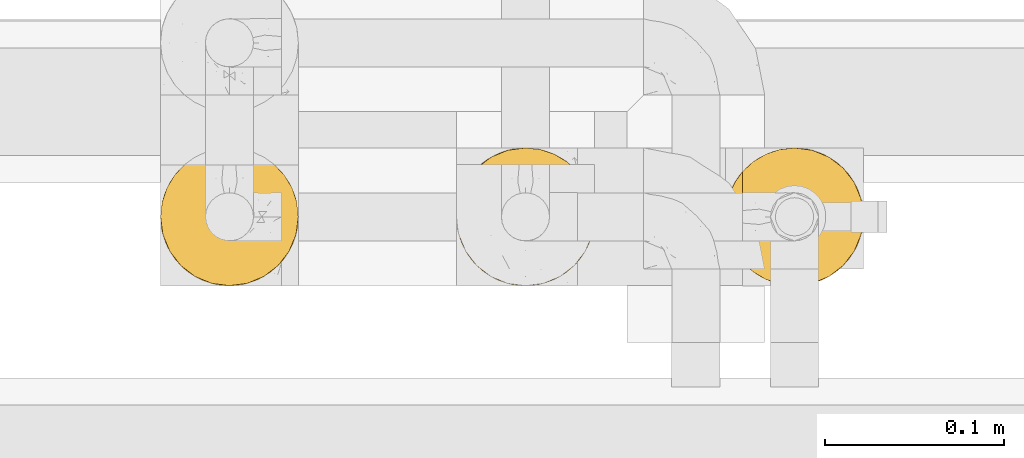
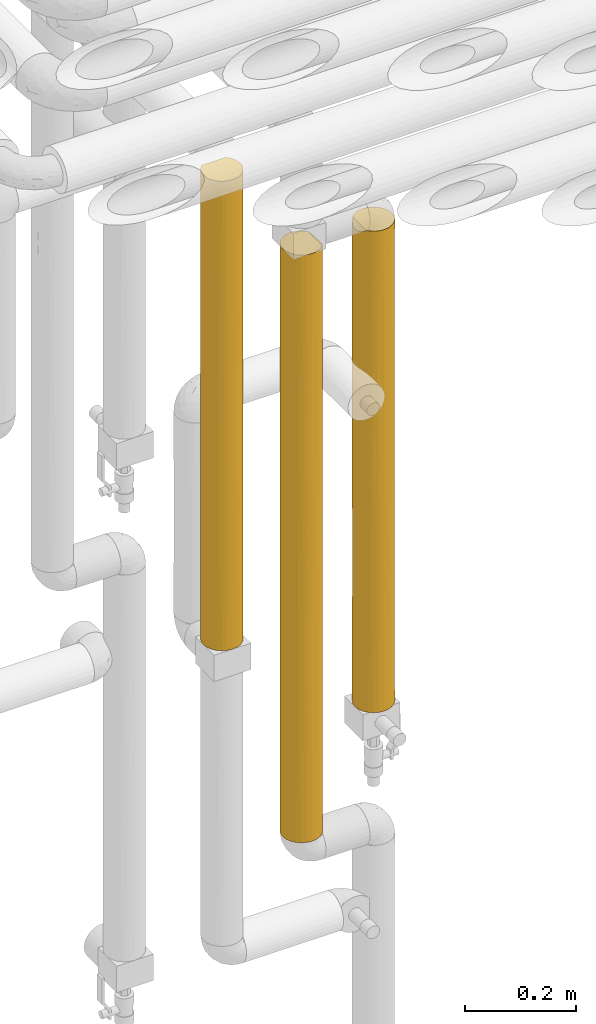
# One storey, part 38 of 827: 3 coverings.
"""IFC2X3 building model written with IfcOpenShell, lengths in millimetres."""

from ifc_helpers import new_model, entity, si_unit, converted_unit, derived_unit, direction, frame, origin, place, context, subcontext, project, spatial, faceted_brep, element, save


model = new_model("IFC2X3")

# Units and contexts
model_context = context("Model", 3, precision=0.01, world=origin(), true_north=direction((6.12303176911189e-17, 1.0)))
body_context = subcontext(model_context, "Body", "Model", "MODEL_VIEW")
ifc_project = project(units=[si_unit("LENGTHUNIT", "METRE", prefix="MILLI"), si_unit("AREAUNIT", "SQUARE_METRE"), si_unit("VOLUMEUNIT", "CUBIC_METRE"), converted_unit("PLANEANGLEUNIT", "DEGREE", entity("IfcRatioMeasure", 0.0174532925199433), si_unit("PLANEANGLEUNIT", "RADIAN"), dimensions=[0, 0, 0, 0, 0, 0, 0]), si_unit("MASSUNIT", "GRAM", prefix="KILO"), derived_unit("MASSDENSITYUNIT", [(si_unit("MASSUNIT", "GRAM", prefix="KILO"), 1), (si_unit("LENGTHUNIT", "METRE"), -3)]), derived_unit("MOMENTOFINERTIAUNIT", [(si_unit("LENGTHUNIT", "METRE"), 4)]), si_unit("TIMEUNIT", "SECOND"), si_unit("FREQUENCYUNIT", "HERTZ"), si_unit("THERMODYNAMICTEMPERATUREUNIT", "DEGREE_CELSIUS"), derived_unit("THERMALTRANSMITTANCEUNIT", [(si_unit("MASSUNIT", "GRAM", prefix="KILO"), 1), (si_unit("THERMODYNAMICTEMPERATUREUNIT", "KELVIN"), -1), (si_unit("TIMEUNIT", "SECOND"), -3)]), derived_unit("VOLUMETRICFLOWRATEUNIT", [(si_unit("LENGTHUNIT", "METRE"), 3), (si_unit("TIMEUNIT", "SECOND"), -1)]), derived_unit("MASSFLOWRATEUNIT", [(si_unit("MASSUNIT", "GRAM", prefix="KILO"), 1), (si_unit("TIMEUNIT", "SECOND"), -1)]), derived_unit("ROTATIONALFREQUENCYUNIT", [(si_unit("TIMEUNIT", "SECOND"), -1)]), si_unit("ELECTRICCURRENTUNIT", "AMPERE"), si_unit("ELECTRICVOLTAGEUNIT", "VOLT"), si_unit("POWERUNIT", "WATT"), si_unit("FORCEUNIT", "NEWTON", prefix="KILO"), si_unit("ILLUMINANCEUNIT", "LUX"), si_unit("LUMINOUSFLUXUNIT", "LUMEN"), si_unit("LUMINOUSINTENSITYUNIT", "CANDELA"), derived_unit("USERDEFINED", [(si_unit("MASSUNIT", "GRAM", prefix="KILO"), -1), (si_unit("LENGTHUNIT", "METRE"), -2), (si_unit("TIMEUNIT", "SECOND"), 3), (si_unit("LUMINOUSFLUXUNIT", "LUMEN"), 1)]), derived_unit("LINEARVELOCITYUNIT", [(si_unit("LENGTHUNIT", "METRE"), 1), (si_unit("TIMEUNIT", "SECOND"), -1)]), si_unit("PRESSUREUNIT", "PASCAL"), derived_unit("USERDEFINED", [(si_unit("LENGTHUNIT", "METRE"), -2), (si_unit("MASSUNIT", "GRAM", prefix="KILO"), 1), (si_unit("TIMEUNIT", "SECOND"), -2)]), derived_unit("LINEARFORCEUNIT", [(si_unit("MASSUNIT", "GRAM", prefix="KILO"), 1), (si_unit("LENGTHUNIT", "METRE"), 1), (si_unit("TIMEUNIT", "SECOND"), -2), (si_unit("LENGTHUNIT", "METRE"), -1)]), derived_unit("PLANARFORCEUNIT", [(si_unit("MASSUNIT", "GRAM", prefix="KILO"), 1), (si_unit("LENGTHUNIT", "METRE"), 1), (si_unit("TIMEUNIT", "SECOND"), -2), (si_unit("LENGTHUNIT", "METRE"), -2)])], contexts=[model_context])

# Site, building, storey
site_placement = place(None, origin())
site = spatial("IfcSite", under=ifc_project, at=site_placement, CompositionType="ELEMENT")
building_placement = place(site_placement, origin())
building = spatial("IfcBuilding", under=site, at=building_placement, CompositionType="ELEMENT")
storey_placement = place(building_placement, frame((0.0, 0.0, 28200.0)))
storey = spatial("IfcBuildingStorey", under=building, at=storey_placement, Name="08", CompositionType="ELEMENT", Elevation=28200.0)

# Coverings
covering_1_placement = place(storey_placement, frame((35102.89, 14884.92, 1492.5)))
element("IfcCovering", 1, at=covering_1_placement, inside=storey, Name=":ADSK_", ObjectType=":ADSK_", PredefinedType="INSULATION", context=body_context, shape_type="Brep", body=[
    faceted_brep([(2.9, 30.06, 0.0), (1.6, 40.0, 0.0), (2.9, 49.93, 0.0), (6.74, 59.2, 0.0), (12.84, 67.15, 0.0), (20.8, 73.25, 0.0), (30.06, 77.09, 0.0), (40.0, 78.4, 0.0), (49.93, 77.09, 0.0), (59.2, 73.25, 0.0), (67.15, 67.15, 0.0), (73.25, 59.2, 0.0), (77.09, 49.93, 0.0), (78.4, 40.0, 0.0), (77.09, 30.06, 0.0), (73.25, 20.8, 0.0), (67.15, 12.84, 0.0), (59.2, 6.74, 0.0), (49.93, 2.9, 0.0), (40.0, 1.6, 0.0), (30.06, 2.9, 0.0), (20.8, 6.74, 0.0), (12.84, 12.84, 0.0), (6.74, 20.8, 0.0), (10.9, 14.94, 1058.4), (16.91, 9.31, 1058.4), (23.98, 5.09, 1058.4), (31.79, 2.48, 1058.4), (40.0, 1.6, 1058.4), (49.93, 2.9, 1058.4), (59.2, 6.74, 1058.4), (67.15, 12.84, 1058.4), (73.25, 20.8, 1058.4), (77.09, 30.06, 1058.4), (78.4, 40.0, 1058.4), (77.09, 49.93, 1058.4), (73.25, 59.2, 1058.4), (67.15, 67.15, 1058.4), (59.2, 73.25, 1058.4), (49.93, 77.09, 1058.4), (40.0, 78.4, 1058.4), (31.79, 77.51, 1058.4), (23.98, 74.9, 1058.4), (16.91, 70.68, 1058.4), (10.9, 65.05, 1058.4), (70.46, 16.62, 813.62), (78.4, 40.0, 312.83), (77.64, 32.43, 237.31), (75.01, 24.24, 875.18), (76.93, 29.5, 733.84), (78.4, 40.0, 842.03), (70.46, 16.62, 244.78), (47.2, 2.28, 733.84), (46.91, 2.22, 494.82), (54.69, 4.52, 446.97), (78.4, 40.0, 625.65), (74.0, 22.15, 671.41), (77.68, 32.64, 469.24), (75.47, 25.3, 324.07), (70.46, 16.62, 529.2), (63.37, 9.53, 734.33), (40.0, 1.6, 625.65), (63.37, 9.53, 293.9), (56.85, 5.49, 225.61), (54.69, 4.52, 799.25), (65.03, 10.88, 514.11), (49.37, 2.76, 252.44), (40.0, 1.6, 842.03), (40.0, 1.6, 432.75), (40.0, 1.6, 312.83), (40.0, 1.6, 216.37), (20.33, 7.01, 855.36), (27.82, 3.58, 790.86), (20.33, 7.01, 620.07), (14.36, 11.4, 737.71), (14.56, 11.23, 498.2), (25.3, 4.52, 313.84), (2.98, 29.79, 742.51), (2.33, 32.52, 462.27), (4.6, 25.11, 549.47), (16.62, 9.53, 257.2), (8.89, 17.48, 800.36), (2.2, 33.21, 1049.7), (1.6, 40.0, 832.73), (32.83, 2.27, 308.29), (2.33, 32.5, 231.69), (1.6, 40.0, 308.18), (31.06, 2.65, 529.2), (4.0, 26.63, 1051.5), (5.45, 23.23, 742.57), (9.53, 16.62, 243.7), (4.52, 25.3, 309.55), (9.0, 17.32, 526.07), (1.6, 40.0, 616.36), (1.6, 40.0, 432.75), (6.92, 20.48, 1054.43), (1.6, 40.0, 216.37), (1.6, 40.0, 1049.1), (5.36, 56.59, 867.73), (4.0, 53.36, 1051.5), (6.92, 59.51, 1054.43), (2.2, 46.78, 1049.7), (2.98, 50.2, 742.51), (4.52, 54.69, 309.55), (9.53, 63.37, 243.7), (8.89, 62.51, 800.36), (2.25, 47.04, 324.56), (3.31, 51.35, 515.31), (9.0, 62.67, 526.07), (14.36, 68.59, 737.71), (20.33, 72.98, 855.36), (40.0, 78.4, 625.65), (40.0, 78.4, 432.74), (31.06, 77.34, 529.2), (27.82, 76.41, 790.86), (5.63, 57.12, 658.7), (20.33, 72.98, 620.07), (40.0, 78.4, 216.37), (32.83, 77.72, 308.29), (25.3, 75.47, 313.84), (16.62, 70.46, 257.2), (40.0, 78.4, 842.02), (14.56, 68.76, 498.2), (40.0, 78.4, 745.57), (63.37, 70.46, 813.62), (54.69, 75.47, 734.33), (63.37, 70.46, 244.78), (70.46, 63.37, 293.9), (69.11, 65.03, 514.11), (75.47, 54.69, 446.97), (54.69, 75.47, 324.07), (56.97, 74.44, 529.2), (47.36, 77.68, 588.94), (47.03, 77.75, 324.56), (70.46, 63.37, 734.33), (77.23, 49.37, 252.44), (77.71, 47.2, 733.84), (77.77, 46.91, 494.82), (47.56, 77.64, 820.76), (74.5, 56.85, 225.61), (63.37, 70.46, 529.2), (75.47, 54.69, 799.25)], [[[0, 1, 2, 3, 4, 5, 6, 7, 8, 9, 10, 11, 12, 13, 14, 15, 16, 17, 18, 19, 20, 21, 22, 23]], [[24, 25, 26, 27, 28, 29, 30, 31, 32, 33, 34, 35, 36, 37, 38, 39, 40, 41, 42, 43, 44]], [[32, 31, 45]], [[13, 46, 47]], [[48, 33, 32]], [[49, 50, 33]], [[15, 51, 16]], [[52, 53, 54]], [[50, 34, 33]], [[49, 55, 50]], [[56, 57, 49]], [[48, 45, 56]], [[14, 58, 15]], [[59, 45, 60]], [[52, 61, 53]], [[62, 17, 16]], [[58, 57, 56]], [[54, 63, 62]], [[31, 30, 60]], [[60, 30, 64]], [[65, 54, 62]], [[54, 66, 63]], [[53, 66, 54]], [[64, 30, 29]], [[55, 57, 46]], [[61, 52, 67]], [[51, 62, 16]], [[59, 51, 58]], [[18, 66, 19]], [[60, 65, 59]], [[67, 52, 29]], [[54, 60, 64]], [[46, 57, 47]], [[60, 45, 31]], [[56, 45, 59]], [[58, 51, 15]], [[51, 59, 65]], [[29, 28, 67]], [[54, 64, 52]], [[29, 52, 64]], [[53, 61, 68, 69]], [[66, 69, 70, 19]], [[69, 66, 53]], [[63, 18, 17]], [[18, 63, 66]], [[17, 62, 63]], [[49, 57, 55]], [[47, 57, 58]], [[58, 14, 47]], [[13, 47, 14]], [[58, 56, 59]], [[48, 56, 49]], [[33, 48, 49]], [[45, 48, 32]], [[54, 65, 60]], [[51, 65, 62]], [[71, 72, 26]], [[73, 74, 75]], [[76, 21, 20]], [[77, 78, 79]], [[73, 80, 76]], [[74, 24, 81]], [[82, 83, 77]], [[27, 72, 67]], [[26, 72, 27]], [[22, 21, 80]], [[20, 70, 84]], [[85, 78, 86]], [[74, 73, 71]], [[76, 87, 73]], [[88, 77, 89]], [[76, 80, 21]], [[71, 26, 25]], [[23, 22, 90]], [[77, 88, 82]], [[72, 61, 67]], [[79, 89, 77]], [[23, 90, 91]], [[92, 75, 74]], [[78, 93, 94, 86]], [[91, 0, 23]], [[95, 88, 89]], [[84, 68, 87]], [[95, 81, 24]], [[87, 61, 72]], [[78, 85, 91]], [[68, 61, 87]], [[28, 27, 67]], [[73, 87, 72]], [[78, 77, 93]], [[0, 85, 1]], [[80, 75, 90]], [[25, 24, 74]], [[72, 71, 73]], [[25, 74, 71]], [[92, 74, 81]], [[80, 90, 22]], [[91, 90, 92]], [[90, 75, 92]], [[80, 73, 75]], [[20, 19, 70]], [[87, 76, 84]], [[78, 91, 79]], [[91, 92, 79]], [[89, 92, 81]], [[85, 86, 96, 1]], [[0, 91, 85]], [[92, 89, 79]], [[89, 81, 95]], [[20, 84, 76]], [[84, 70, 69, 68]], [[83, 82, 97]], [[83, 93, 77]], [[98, 99, 100]], [[101, 99, 102]], [[103, 3, 2]], [[4, 3, 104]], [[97, 101, 83]], [[100, 44, 105]], [[101, 102, 83]], [[103, 106, 107]], [[108, 105, 109]], [[110, 109, 43]], [[107, 93, 102]], [[111, 112, 113]], [[106, 96, 86, 94]], [[2, 96, 106]], [[114, 42, 41]], [[103, 107, 115]], [[110, 114, 116]], [[112, 117, 118]], [[119, 6, 5]], [[98, 105, 115]], [[120, 116, 119]], [[44, 43, 109]], [[113, 114, 111]], [[120, 119, 5]], [[4, 120, 5]], [[108, 103, 115]], [[110, 43, 42]], [[104, 103, 108]], [[119, 113, 118]], [[113, 116, 114]], [[6, 117, 7]], [[116, 113, 119]], [[41, 121, 114]], [[104, 120, 4]], [[122, 108, 109]], [[114, 110, 42]], [[109, 110, 116]], [[109, 116, 122]], [[109, 105, 44]], [[103, 104, 3]], [[104, 108, 122]], [[116, 120, 122]], [[104, 122, 120]], [[2, 1, 96]], [[94, 93, 107]], [[2, 106, 103]], [[107, 106, 94]], [[107, 102, 115]], [[98, 102, 99]], [[105, 108, 115]], [[105, 98, 100]], [[102, 98, 115]], [[118, 6, 119]], [[112, 118, 113]], [[6, 118, 117]], [[102, 93, 83]], [[121, 41, 40]], [[114, 121, 123, 111]], [[124, 125, 38]], [[126, 127, 10]], [[128, 129, 127]], [[130, 131, 126]], [[38, 125, 39]], [[125, 131, 132]], [[37, 124, 38]], [[112, 133, 117]], [[126, 10, 9]], [[9, 8, 130]], [[36, 134, 37]], [[12, 135, 13]], [[136, 55, 137]], [[131, 125, 124]], [[132, 138, 125]], [[129, 139, 127]], [[135, 139, 129]], [[127, 11, 10]], [[140, 124, 134]], [[55, 136, 50]], [[137, 135, 129]], [[141, 134, 36]], [[8, 117, 133]], [[130, 133, 132]], [[141, 36, 35]], [[136, 137, 129]], [[134, 128, 140]], [[50, 136, 35]], [[39, 138, 40]], [[129, 134, 141]], [[130, 126, 9]], [[126, 140, 128]], [[134, 124, 37]], [[124, 140, 126, 131]], [[8, 7, 117]], [[133, 112, 132]], [[8, 133, 130]], [[132, 112, 111, 123]], [[138, 132, 123]], [[35, 34, 50]], [[129, 141, 136]], [[35, 136, 141]], [[55, 46, 137]], [[46, 13, 135]], [[46, 135, 137]], [[139, 12, 11]], [[12, 139, 135]], [[11, 127, 139]], [[138, 123, 121, 40]], [[39, 125, 138]], [[132, 131, 130]], [[129, 128, 134]], [[126, 128, 127]], [[101, 97, 82, 88, 95, 24, 44, 100, 99]]]),
])
covering_2_placement = place(storey_placement, frame((34952.89, 14884.92, 1257.5)))
element("IfcCovering", 2, at=covering_2_placement, inside=storey, Name=":ADSK_", ObjectType=":ADSK_", PredefinedType="INSULATION", context=body_context, shape_type="Brep", body=[
    faceted_brep([(6.74, 20.8, 1.6), (2.9, 30.06, 1.6), (1.6, 40.0, 1.6), (2.9, 49.93, 1.6), (6.74, 59.2, 1.6), (12.84, 67.15, 1.6), (20.8, 73.25, 1.6), (30.06, 77.09, 1.6), (40.0, 78.4, 1.6), (48.2, 77.51, 1.6), (56.01, 74.9, 1.6), (63.08, 70.68, 1.6), (69.1, 65.05, 1.6), (69.1, 14.94, 1.6), (63.08, 9.31, 1.6), (56.01, 5.09, 1.6), (48.2, 2.48, 1.6), (40.0, 1.6, 1.6), (30.06, 2.9, 1.6), (20.8, 6.74, 1.6), (12.84, 12.84, 1.6), (48.16, 2.47, 1293.5), (55.94, 5.06, 1293.5), (62.99, 9.24, 1293.5), (69.0, 14.82, 1293.5), (69.0, 65.17, 1293.5), (62.99, 70.75, 1293.5), (55.94, 74.93, 1293.5), (48.16, 77.52, 1293.5), (40.0, 78.4, 1293.5), (30.06, 77.09, 1293.5), (20.8, 73.25, 1293.5), (12.84, 67.15, 1293.5), (6.74, 59.2, 1293.5), (2.9, 49.93, 1293.5), (1.6, 40.0, 1293.5), (2.9, 30.06, 1293.5), (6.74, 20.8, 1293.5), (12.84, 12.84, 1293.5), (20.8, 6.74, 1293.5), (30.06, 2.9, 1293.5), (40.0, 1.6, 1293.5), (77.78, 33.17, 1284.71), (75.97, 26.56, 1286.52), (77.48, 31.68, 972.05), (59.58, 6.96, 1107.11), (66.14, 11.87, 1038.3), (52.17, 3.58, 277.97), (40.0, 1.6, 217.97), (66.24, 11.96, 277.98), (59.66, 7.01, 216.52), (73.01, 20.38, 1289.48), (74.55, 23.24, 942.55), (70.47, 16.64, 908.31), (78.4, 40.0, 1067.72), (78.4, 40.0, 876.39), (52.12, 3.56, 1038.32), (59.58, 6.96, 886.32), (76.54, 28.2, 648.87), (74.59, 23.33, 353.75), (77.52, 31.84, 335.45), (78.4, 40.0, 227.27), (78.4, 40.0, 443.64), (71.31, 17.78, 216.97), (73.07, 20.48, 5.57), (66.0, 11.74, 786.74), (65.83, 11.58, 548.84), (70.86, 17.15, 647.83), (76.0, 26.63, 8.5), (77.79, 33.21, 10.29), (71.01, 17.35, 432.2), (40.0, 1.6, 428.0), (52.92, 3.84, 494.01), (60.93, 7.8, 674.6), (59.66, 7.01, 462.3), (50.4, 3.03, 697.42), (40.0, 1.6, 1077.12), (78.4, 40.0, 1284.1), (78.4, 40.0, 10.9), (78.4, 40.0, 660.01), (40.0, 1.6, 860.75), (40.0, 1.6, 650.71), (40.0, 1.6, 644.38), (40.0, 1.6, 434.34), (40.0, 1.6, 867.09), (16.62, 9.53, 1034.3), (9.53, 16.62, 969.22), (32.88, 2.26, 326.15), (31.56, 2.53, 650.71), (25.3, 4.52, 373.29), (25.3, 4.52, 921.8), (32.84, 2.27, 972.1), (1.6, 40.0, 1077.12), (1.6, 40.0, 217.97), (23.7, 5.22, 684.79), (1.6, 40.0, 428.0), (2.27, 32.83, 322.99), (4.52, 25.3, 1048.44), (6.84, 20.62, 572.76), (11.32, 14.46, 577.99), (7.88, 18.94, 777.8), (2.29, 32.71, 968.94), (4.52, 25.3, 763.78), (9.53, 16.62, 373.29), (4.52, 25.3, 272.12), (16.62, 9.53, 272.12), (16.62, 9.53, 647.55), (3.48, 28.11, 517.95), (2.22, 33.12, 731.85), (12.38, 13.31, 791.26), (17.3, 9.02, 840.92), (1.6, 40.0, 867.09), (1.6, 40.0, 860.75), (1.6, 40.0, 644.38), (1.6, 40.0, 434.34), (1.6, 40.0, 650.71), (9.53, 63.37, 1034.3), (16.62, 70.46, 969.22), (2.26, 47.12, 326.15), (2.53, 48.43, 650.71), (4.52, 54.69, 373.29), (4.52, 54.69, 921.8), (2.27, 47.15, 972.1), (40.0, 78.4, 1077.12), (40.0, 78.4, 217.97), (40.0, 78.4, 214.8), (5.22, 56.29, 684.79), (40.0, 78.4, 428.0), (32.83, 77.72, 322.99), (25.3, 75.47, 1048.44), (20.62, 73.15, 572.76), (14.46, 68.67, 577.99), (18.94, 72.11, 777.8), (32.71, 77.7, 968.94), (25.3, 75.47, 763.78), (16.62, 70.46, 373.29), (25.3, 75.47, 272.12), (9.53, 63.37, 272.12), (9.53, 63.37, 647.55), (28.11, 76.51, 517.95), (33.12, 77.77, 731.85), (13.31, 67.61, 791.26), (9.02, 62.69, 840.92), (40.0, 78.4, 860.75), (40.0, 78.4, 644.37), (52.12, 76.43, 1015.67), (74.55, 56.75, 943.52), (70.97, 62.69, 863.0), (71.23, 62.33, 1078.4), (59.58, 73.03, 828.13), (59.58, 73.03, 1078.96), (65.9, 68.35, 749.13), (66.06, 68.19, 508.81), (60.97, 72.16, 617.52), (73.01, 59.61, 1289.48), (59.66, 72.98, 186.49), (66.24, 68.03, 256.35), (66.14, 68.12, 1015.66), (76.0, 53.36, 8.5), (73.07, 59.51, 5.57), (74.59, 56.66, 352.23), (52.17, 76.41, 256.35), (75.97, 53.43, 1286.52), (77.78, 46.82, 1284.71), (77.48, 48.31, 972.05), (59.66, 72.98, 406.31), (50.42, 76.95, 603.65), (70.53, 63.27, 387.8), (47.86, 77.58, 822.29), (70.94, 62.73, 647.24), (77.79, 46.78, 10.29), (77.52, 48.15, 335.45), (76.52, 51.85, 648.58)], [[[0, 1, 2, 3, 4, 5, 6, 7, 8, 9, 10, 11, 12, 13, 14, 15, 16, 17, 18, 19, 20]], [[21, 22, 23, 24, 25, 26, 27, 28, 29, 30, 31, 32, 33, 34, 35, 36, 37, 38, 39, 40, 41]], [[42, 43, 44]], [[45, 46, 23]], [[46, 24, 23]], [[47, 48, 16]], [[14, 49, 50]], [[43, 51, 52]], [[53, 24, 46]], [[54, 44, 55]], [[45, 56, 57]], [[58, 59, 60]], [[61, 62, 60]], [[63, 64, 59]], [[65, 66, 67]], [[15, 47, 16]], [[68, 59, 64]], [[46, 65, 53]], [[61, 60, 69]], [[59, 70, 63]], [[71, 47, 72]], [[66, 65, 73]], [[63, 13, 64]], [[50, 15, 14]], [[74, 47, 50]], [[45, 23, 22]], [[56, 75, 57]], [[21, 76, 56]], [[54, 77, 42]], [[58, 67, 59]], [[49, 14, 13]], [[52, 67, 58]], [[22, 21, 56]], [[72, 47, 74]], [[16, 48, 17]], [[68, 69, 60]], [[69, 78, 61]], [[58, 60, 62]], [[60, 59, 68]], [[79, 55, 58, 62]], [[55, 44, 58]], [[75, 80, 81, 82, 83, 71]], [[75, 56, 80]], [[75, 72, 73]], [[65, 46, 57]], [[53, 51, 24]], [[44, 43, 52]], [[42, 44, 54]], [[58, 44, 52]], [[56, 45, 22]], [[71, 48, 47]], [[46, 45, 57]], [[73, 65, 57]], [[53, 67, 52]], [[74, 49, 66]], [[70, 49, 63]], [[67, 53, 65]], [[51, 53, 52]], [[75, 73, 57]], [[66, 73, 74]], [[74, 50, 49]], [[15, 50, 47]], [[70, 59, 67]], [[13, 63, 49]], [[67, 66, 70]], [[49, 70, 66]], [[76, 21, 41]], [[56, 76, 84, 80]], [[73, 72, 74]], [[71, 72, 75]], [[85, 38, 86]], [[87, 88, 89]], [[18, 48, 87]], [[18, 89, 19]], [[40, 39, 90]], [[91, 40, 90]], [[36, 35, 92]], [[1, 93, 2]], [[83, 88, 87]], [[89, 88, 94]], [[95, 93, 96]], [[37, 97, 86]], [[98, 99, 100]], [[97, 101, 102]], [[40, 76, 41]], [[18, 17, 48]], [[87, 48, 71, 83]], [[103, 104, 0]], [[105, 20, 19]], [[37, 36, 97]], [[37, 86, 38]], [[89, 105, 19]], [[103, 0, 20]], [[1, 0, 104]], [[105, 106, 99]], [[102, 107, 98]], [[108, 107, 102]], [[38, 85, 39]], [[102, 101, 108]], [[109, 110, 85]], [[98, 107, 104]], [[106, 105, 89]], [[103, 20, 105]], [[85, 86, 109]], [[90, 39, 85]], [[92, 101, 36]], [[97, 102, 100]], [[101, 92, 111, 112]], [[101, 112, 108]], [[36, 101, 97]], [[107, 113, 114, 95]], [[96, 107, 95]], [[108, 113, 107]], [[98, 104, 103]], [[103, 99, 98]], [[109, 100, 99]], [[108, 112, 115, 113]], [[105, 99, 103]], [[109, 99, 106]], [[109, 106, 110]], [[109, 86, 100]], [[97, 100, 86]], [[98, 100, 102]], [[88, 83, 82, 81, 80, 84]], [[18, 87, 89]], [[91, 88, 84]], [[88, 90, 94]], [[40, 91, 76]], [[84, 76, 91]], [[88, 91, 90]], [[96, 1, 104]], [[1, 96, 93]], [[107, 96, 104]], [[94, 110, 106]], [[90, 85, 110]], [[110, 94, 90]], [[89, 94, 106]], [[116, 32, 117]], [[118, 119, 120]], [[3, 93, 118]], [[3, 120, 4]], [[34, 33, 121]], [[122, 34, 121]], [[30, 29, 123]], [[7, 124, 125, 8]], [[114, 119, 118]], [[120, 119, 126]], [[127, 124, 128]], [[31, 129, 117]], [[130, 131, 132]], [[129, 133, 134]], [[34, 92, 35]], [[3, 2, 93]], [[118, 93, 95, 114]], [[135, 136, 6]], [[137, 5, 4]], [[31, 30, 129]], [[31, 117, 32]], [[120, 137, 4]], [[135, 6, 5]], [[7, 6, 136]], [[137, 138, 131]], [[134, 139, 130]], [[140, 139, 134]], [[32, 116, 33]], [[134, 133, 140]], [[141, 142, 116]], [[130, 139, 136]], [[138, 137, 120]], [[135, 5, 137]], [[116, 117, 141]], [[121, 33, 116]], [[123, 133, 30]], [[129, 134, 132]], [[133, 123, 143]], [[133, 143, 140]], [[30, 133, 129]], [[139, 144, 127]], [[128, 139, 127]], [[140, 144, 139]], [[130, 136, 135]], [[135, 131, 130]], [[141, 132, 131]], [[140, 143, 144]], [[137, 131, 135]], [[141, 131, 138]], [[141, 138, 142]], [[141, 117, 132]], [[129, 132, 117]], [[130, 132, 134]], [[119, 114, 113, 115, 112, 111]], [[3, 118, 120]], [[122, 119, 111]], [[119, 121, 126]], [[34, 122, 92]], [[111, 92, 122]], [[119, 122, 121]], [[128, 7, 136]], [[7, 128, 124]], [[139, 128, 136]], [[126, 142, 138]], [[121, 116, 142]], [[142, 126, 121]], [[120, 126, 138]], [[145, 123, 28]], [[146, 147, 148]], [[149, 145, 150]], [[151, 152, 153]], [[148, 25, 154]], [[11, 155, 156]], [[26, 157, 150]], [[123, 29, 28]], [[158, 159, 160]], [[9, 125, 161]], [[162, 163, 164]], [[27, 145, 28]], [[165, 161, 166]], [[11, 10, 155]], [[156, 152, 167]], [[168, 149, 166]], [[151, 169, 152]], [[150, 27, 26]], [[170, 171, 61]], [[25, 157, 26]], [[171, 160, 172]], [[164, 163, 54]], [[143, 123, 168, 144]], [[165, 155, 161]], [[54, 55, 164]], [[170, 158, 171]], [[167, 12, 156]], [[146, 148, 154]], [[11, 156, 12]], [[172, 169, 146]], [[61, 78, 170]], [[146, 154, 162]], [[10, 9, 161]], [[172, 55, 79, 62]], [[171, 158, 160]], [[62, 61, 171]], [[160, 169, 172]], [[163, 77, 54]], [[172, 62, 171]], [[149, 168, 145]], [[166, 161, 127]], [[166, 127, 144]], [[153, 166, 149]], [[152, 156, 165]], [[167, 159, 12]], [[164, 172, 146]], [[125, 9, 8]], [[164, 146, 162]], [[161, 155, 10]], [[156, 155, 165]], [[153, 152, 165]], [[167, 169, 160]], [[149, 157, 151]], [[147, 157, 148]], [[169, 167, 152]], [[159, 167, 160]], [[166, 153, 165]], [[151, 153, 149]], [[149, 150, 157]], [[27, 150, 145]], [[147, 146, 169]], [[25, 148, 157]], [[169, 151, 147]], [[157, 147, 151]], [[168, 123, 145]], [[55, 172, 164]], [[161, 125, 124, 127]], [[144, 168, 166]], [[12, 159, 158, 170, 78, 69, 68, 64, 13]], [[24, 51, 43, 42, 77, 163, 162, 154, 25]]]),
])
covering_3_placement = place(storey_placement, frame((34787.85, 14884.92, 1737.4)))
element("IfcCovering", 3, at=covering_3_placement, inside=storey, Name=":ADSK_", ObjectType=":ADSK_", PredefinedType="INSULATION", context=body_context, shape_type="Brep", body=[
    faceted_brep([(73.25, 20.8, 1033.5), (77.09, 30.06, 1033.5), (78.4, 40.0, 1033.5), (77.51, 48.2, 1033.5), (74.9, 56.01, 1033.5), (70.68, 63.08, 1033.5), (65.05, 69.1, 1033.5), (14.94, 69.1, 1033.5), (9.31, 63.08, 1033.5), (5.09, 56.01, 1033.5), (2.48, 48.2, 1033.5), (1.6, 40.0, 1033.5), (2.9, 30.06, 1033.5), (6.74, 20.8, 1033.5), (12.84, 12.84, 1033.5), (20.8, 6.74, 1033.5), (30.06, 2.9, 1033.5), (40.0, 1.6, 1033.5), (49.93, 2.9, 1033.5), (59.2, 6.74, 1033.5), (67.15, 12.84, 1033.5), (74.93, 55.94, 1.6), (77.52, 48.16, 1.6), (78.4, 40.0, 1.6), (77.09, 30.06, 1.6), (73.25, 20.8, 1.6), (67.15, 12.84, 1.6), (59.2, 6.74, 1.6), (49.93, 2.9, 1.6), (40.0, 1.6, 1.6), (30.06, 2.9, 1.6), (20.8, 6.74, 1.6), (12.84, 12.84, 1.6), (6.74, 20.8, 1.6), (2.9, 30.06, 1.6), (1.6, 40.0, 1.6), (2.47, 48.16, 1.6), (5.06, 55.94, 1.6), (9.24, 62.99, 1.6), (14.82, 69.0, 1.6), (65.17, 69.0, 1.6), (70.75, 62.99, 1.6), (76.41, 52.17, 702.15), (78.4, 40.0, 434.34), (77.02, 50.18, 326.15), (73.03, 59.58, 204.86), (50.28, 76.99, 369.34), (40.0, 78.4, 591.45), (50.2, 77.01, 717.61), (59.61, 73.01, 5.61), (62.62, 71.02, 251.23), (73.03, 59.58, 440.06), (68.63, 65.58, 322.46), (69.13, 65.01, 656.21), (73.16, 59.36, 807.44), (62.66, 70.99, 517.91), (62.51, 71.1, 784.12), (78.4, 40.0, 733.92), (46.78, 77.79, 1024.8), (40.0, 78.4, 807.82), (40.0, 78.4, 1024.2), (78.4, 40.0, 217.97), (53.43, 75.97, 8.57), (55.51, 75.12, 218.77), (46.82, 77.78, 10.38), (53.36, 76.0, 1026.6), (59.51, 73.07, 1029.52), (57.16, 74.34, 647.32), (40.0, 78.4, 301.22), (56.84, 74.5, 434.6), (40.0, 78.4, 11.0), (24.48, 75.12, 218.77), (33.17, 77.78, 10.38), (26.56, 75.97, 8.57), (20.38, 73.01, 5.61), (17.37, 71.02, 251.23), (33.21, 77.79, 1024.8), (29.79, 77.01, 717.61), (26.63, 76.0, 1026.6), (3.58, 52.17, 702.15), (1.6, 40.0, 733.92), (6.55, 58.87, 655.29), (23.15, 74.5, 434.6), (29.71, 76.99, 369.34), (11.36, 65.58, 322.46), (17.33, 70.99, 517.91), (2.5, 48.27, 485.88), (22.83, 74.34, 647.32), (6.96, 59.58, 204.86), (17.48, 71.1, 784.12), (20.48, 73.07, 1029.52), (3.56, 52.12, 268.74), (1.6, 40.0, 217.97), (6.96, 59.58, 440.06), (10.86, 65.01, 656.21), (1.6, 40.0, 817.12), (1.6, 40.0, 301.17), (1.6, 40.0, 434.34), (1.6, 40.0, 600.75), (9.53, 16.62, 239.24), (4.52, 25.3, 320.57), (9.53, 16.62, 795.85), (16.62, 9.53, 742.08), (14.78, 11.04, 531.33), (25.3, 4.52, 593.84), (4.52, 25.3, 714.52), (5.64, 22.84, 517.55), (2.29, 32.75, 450.96), (2.24, 32.96, 708.94), (16.62, 9.53, 320.57), (30.07, 2.9, 789.72), (32.79, 2.28, 326.15), (40.0, 1.6, 434.34), (33.12, 2.22, 563.26), (2.33, 32.54, 220.29), (22.89, 5.61, 802.02), (9.53, 16.62, 517.55), (40.0, 1.6, 217.97), (40.0, 1.6, 301.17), (25.3, 4.52, 259.75), (40.0, 1.6, 600.75), (40.0, 1.6, 733.92), (40.0, 1.6, 817.12), (63.37, 9.53, 239.24), (54.69, 4.52, 320.57), (63.37, 9.53, 795.85), (70.46, 16.62, 742.08), (68.96, 14.78, 531.33), (75.47, 25.3, 593.84), (54.69, 4.52, 714.52), (57.15, 5.64, 517.55), (47.24, 2.29, 450.96), (47.03, 2.24, 708.94), (70.46, 16.62, 320.57), (77.09, 30.07, 789.72), (77.71, 32.79, 326.15), (77.77, 33.12, 563.26), (47.45, 2.33, 220.29), (74.38, 22.89, 802.02), (63.37, 9.53, 517.55), (75.47, 25.3, 259.75)], [[[0, 1, 2, 3, 4, 5, 6, 7, 8, 9, 10, 11, 12, 13, 14, 15, 16, 17, 18, 19, 20]], [[21, 22, 23, 24, 25, 26, 27, 28, 29, 30, 31, 32, 33, 34, 35, 36, 37, 38, 39, 40, 41]], [[42, 43, 44]], [[4, 3, 42]], [[41, 45, 21]], [[46, 47, 48]], [[40, 49, 50]], [[51, 52, 53]], [[51, 54, 42]], [[44, 51, 42]], [[55, 56, 53]], [[3, 57, 42]], [[53, 6, 5]], [[58, 59, 60]], [[54, 4, 42]], [[61, 22, 44]], [[52, 51, 45]], [[49, 62, 63]], [[64, 46, 63]], [[44, 43, 61]], [[58, 48, 59]], [[58, 65, 48]], [[66, 56, 67]], [[64, 68, 46]], [[69, 46, 48]], [[54, 51, 53]], [[48, 47, 59]], [[67, 69, 48]], [[66, 67, 65]], [[40, 50, 52]], [[56, 66, 6]], [[45, 44, 21]], [[61, 23, 22]], [[46, 69, 63]], [[21, 44, 22]], [[67, 56, 55]], [[55, 53, 52]], [[6, 53, 56]], [[5, 4, 54]], [[41, 40, 52]], [[44, 45, 51]], [[41, 52, 45]], [[55, 52, 50]], [[67, 55, 69]], [[65, 67, 48]], [[55, 50, 69]], [[63, 62, 64]], [[69, 50, 63]], [[49, 63, 50]], [[68, 64, 70]], [[68, 47, 46]], [[57, 3, 2]], [[57, 43, 42]], [[5, 54, 53]], [[71, 72, 73]], [[74, 39, 75]], [[76, 77, 78]], [[79, 80, 10]], [[81, 9, 8]], [[70, 72, 68]], [[71, 82, 83]], [[68, 72, 83]], [[84, 85, 75]], [[86, 80, 79]], [[77, 87, 78]], [[84, 38, 88]], [[76, 59, 77]], [[71, 74, 75]], [[89, 7, 90]], [[91, 92, 86]], [[37, 36, 91]], [[39, 38, 84]], [[88, 91, 93]], [[90, 78, 87]], [[84, 94, 85]], [[81, 8, 94]], [[89, 94, 7]], [[37, 88, 38]], [[36, 92, 91]], [[89, 85, 94]], [[86, 93, 91]], [[82, 87, 77]], [[79, 10, 9]], [[47, 83, 77]], [[10, 80, 95, 11]], [[82, 85, 87]], [[86, 92, 96, 97, 98, 80]], [[89, 87, 85]], [[81, 94, 93]], [[7, 94, 8]], [[91, 88, 37]], [[84, 88, 93]], [[84, 93, 94]], [[84, 75, 39]], [[87, 89, 90]], [[82, 77, 83]], [[83, 72, 71]], [[75, 85, 82]], [[74, 71, 73]], [[75, 82, 71]], [[83, 47, 68]], [[59, 76, 60]], [[59, 47, 77]], [[92, 36, 35]], [[93, 86, 79]], [[93, 79, 81]], [[9, 81, 79]], [[99, 100, 33]], [[101, 102, 14]], [[103, 104, 102]], [[105, 106, 101]], [[33, 100, 34]], [[98, 107, 108]], [[32, 99, 33]], [[108, 95, 80, 98]], [[101, 14, 13]], [[13, 12, 105]], [[31, 109, 32]], [[16, 110, 17]], [[111, 112, 113]], [[106, 100, 99]], [[114, 100, 107]], [[104, 115, 102]], [[110, 115, 104]], [[102, 15, 14]], [[116, 99, 109]], [[111, 117, 118, 112]], [[113, 110, 104]], [[119, 109, 31]], [[12, 95, 108]], [[105, 108, 107]], [[119, 31, 30]], [[111, 113, 104]], [[109, 103, 116]], [[117, 111, 30]], [[34, 114, 35]], [[104, 109, 119]], [[105, 101, 13]], [[101, 116, 103]], [[109, 99, 32]], [[99, 116, 101, 106]], [[12, 11, 95]], [[107, 98, 97, 96]], [[12, 108, 105]], [[114, 107, 96]], [[107, 100, 106]], [[30, 29, 117]], [[104, 119, 111]], [[30, 111, 119]], [[113, 112, 120, 121]], [[110, 121, 122, 17]], [[121, 110, 113]], [[115, 16, 15]], [[16, 115, 110]], [[15, 102, 115]], [[114, 96, 92, 35]], [[100, 114, 34]], [[107, 106, 105]], [[104, 103, 109]], [[101, 103, 102]], [[123, 124, 27]], [[125, 126, 20]], [[127, 128, 126]], [[129, 130, 125]], [[27, 124, 28]], [[120, 131, 132]], [[26, 123, 27]], [[132, 122, 121, 120]], [[125, 20, 19]], [[19, 18, 129]], [[25, 133, 26]], [[1, 134, 2]], [[135, 43, 136]], [[130, 124, 123]], [[137, 124, 131]], [[128, 138, 126]], [[134, 138, 128]], [[126, 0, 20]], [[139, 123, 133]], [[43, 135, 61]], [[136, 134, 128]], [[140, 133, 25]], [[18, 122, 132]], [[129, 132, 131]], [[140, 25, 24]], [[135, 136, 128]], [[133, 127, 139]], [[61, 135, 24]], [[28, 137, 29]], [[128, 133, 140]], [[129, 125, 19]], [[125, 139, 127]], [[133, 123, 26]], [[123, 139, 125, 130]], [[18, 17, 122]], [[131, 120, 112, 118]], [[18, 132, 129]], [[137, 131, 118]], [[131, 124, 130]], [[24, 23, 61]], [[128, 140, 135]], [[24, 135, 140]], [[43, 57, 136]], [[57, 2, 134]], [[57, 134, 136]], [[138, 1, 0]], [[1, 138, 134]], [[0, 126, 138]], [[137, 118, 117, 29]], [[124, 137, 28]], [[131, 130, 129]], [[128, 127, 133]], [[125, 127, 126]], [[66, 65, 58, 60, 76, 78, 90, 7, 6]], [[74, 73, 72, 70, 64, 62, 49, 40, 39]]]),
])

save(model, "model.ifc")
